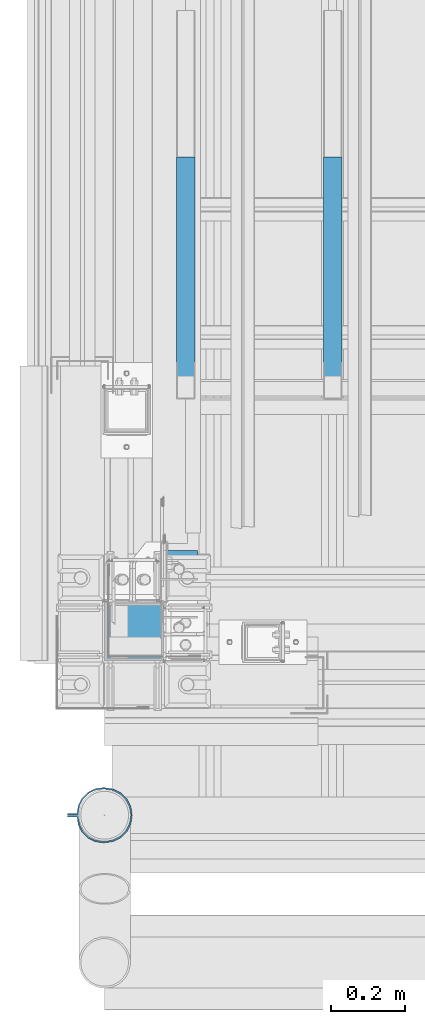
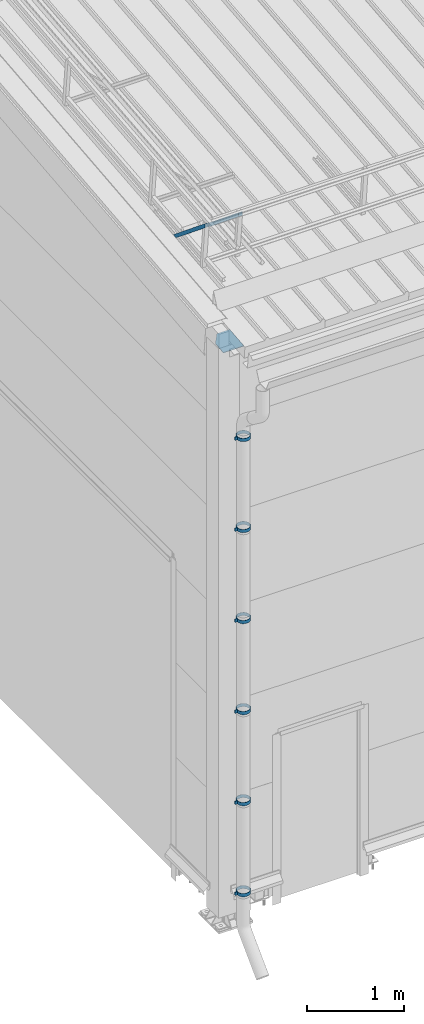
# One storey, part 290 of 709: 7 beams, 2 members, 9 elements without a shape of their own.
"""IFC4 building model written with IfcOpenShell, lengths in millimetres."""

import ifcopenshell
import ifcopenshell.guid

model = None  # the IFC model being written
_history = None  # IfcOwnerHistory: only IFC2X3 demands one
_inside = {}  # id of a spatial element -> (the spatial element, [elements in it])
_under = {}  # id of a project, library or spatial element -> (it, [spatial elements below it])
_declared = {}  # id of a project -> (the project, [libraries it declares])
_typed = {}  # id of a type object -> (the type object, [elements of that type])
_made_of = {}  # id of a material, layer set ... -> (it, [elements and type objects made of it])


def new_model(schema):
    """Start an empty IFC model of exactly this schema.

    Asked for "IFC4X3", IfcOpenShell would pick the latest addendum, in which some entities
    have other attributes; the version numbers below select the first issue.
    IFC2X3 requires an IfcOwnerHistory on every rooted entity: one is made here for all.
    """
    global model, _history
    if schema == "IFC4X3":
        model = ifcopenshell.file(schema_version=(4, 3, 0, 0))
    else:
        model = ifcopenshell.file(schema=schema)
    _inside.clear()
    _under.clear()
    _declared.clear()
    _typed.clear()
    _made_of.clear()
    _history = None
    if model.schema == "IFC2X3":
        org = make("IfcOrganization", Name="unknown")
        user = make(
            "IfcPersonAndOrganization",
            ThePerson=make("IfcPerson", FamilyName="unknown"),
            TheOrganization=org,
        )
        app = make(
            "IfcApplication",
            ApplicationDeveloper=org,
            Version="unknown",
            ApplicationFullName="unknown",
            ApplicationIdentifier="unknown",
        )
        _history = make(
            "IfcOwnerHistory",
            OwningUser=user,
            OwningApplication=app,
            ChangeAction="ADDED",
            CreationDate=0,
        )
    return model


def make(cls, **values):
    """One entity of the class cls with the attributes given. An attribute that is None is left unset."""
    return model.create_entity(
        cls, **{name: value for name, value in values.items() if value is not None}
    )


def rooted(cls, **values):
    """An entity with a GlobalId (a new one), such as an element, a storey or a relation."""
    return make(cls, GlobalId=ifcopenshell.guid.new(), OwnerHistory=_history, **values)


def si_unit(unit_type, name, prefix=None):
    """IfcSIUnit, for example si_unit("LENGTHUNIT", "METRE", prefix="MILLI")."""
    return make("IfcSIUnit", UnitType=unit_type, Prefix=prefix, Name=name)


def assignment(units):
    """IfcUnitAssignment: the units of a project."""
    return None if units is None else make("IfcUnitAssignment", Units=units)


def point(xyz):
    """IfcCartesianPoint."""
    return None if xyz is None else make("IfcCartesianPoint", Coordinates=xyz)


def direction(xyz):
    """IfcDirection."""
    return None if xyz is None else make("IfcDirection", DirectionRatios=xyz)


def frame(location, z_axis=None, x_axis=None):
    """IfcAxis2Placement3D, a coordinate frame: its origin and axes. An axis left out is left unset."""
    return make(
        "IfcAxis2Placement3D",
        Location=point(location),
        Axis=direction(z_axis),
        RefDirection=direction(x_axis),
    )


def origin_with_axes():
    """The frame at (0, 0, 0) with the z axis (0, 0, 1) and the x axis (1, 0, 0) written out."""
    return frame((0.0, 0.0, 0.0), z_axis=(0.0, 0.0, 1.0), x_axis=(1.0, 0.0, 0.0))


def place(relative_to, where):
    """IfcLocalPlacement: puts the frame where relative to a parent placement (None: the world)."""
    return make(
        "IfcLocalPlacement", PlacementRelTo=relative_to, RelativePlacement=where
    )


def context(
    kind, dimensions, precision=None, world=None, true_north=None, identifier=None
):
    """IfcGeometricRepresentationContext, for example the 3D "Model" context."""
    return make(
        "IfcGeometricRepresentationContext",
        ContextIdentifier=identifier,
        ContextType=kind,
        CoordinateSpaceDimension=dimensions,
        Precision=precision,
        WorldCoordinateSystem=world,
        TrueNorth=true_north,
    )


def subcontext(parent, identifier, kind, view, scale=None):
    """IfcGeometricRepresentationSubContext, for example "Body" below "Model"."""
    return make(
        "IfcGeometricRepresentationSubContext",
        ContextIdentifier=identifier,
        ContextType=kind,
        ParentContext=parent,
        TargetScale=scale,
        TargetView=view,
    )


def project(units=None, contexts=None):
    """IfcProject with its units and contexts."""
    return rooted(
        "IfcProject",
        Name="project",
        RepresentationContexts=contexts,
        UnitsInContext=assignment(units),
    )


def spatial(cls, under=None, at=None, **own):
    """A site, building, storey or space (cls), placed at a placement, below another one or the project."""
    s = rooted(cls, ObjectPlacement=at, **own)
    if under is not None:
        _under.setdefault(under.id(), (under, []))[1].append(s)
    return s


def point_list(points):
    """IfcCartesianPointList2D or 3D."""
    cls = (
        "IfcCartesianPointList2D" if len(points[0]) == 2 else "IfcCartesianPointList3D"
    )
    return make(cls, CoordList=points)


def polygons(points, faces, closed=None, point_numbers=None):
    """IfcPolygonalFaceSet: a face is its outer loop, then its inner loops; points numbered from 1."""
    made = []
    for loops in faces:
        if len(loops) == 1:
            made.append(make("IfcIndexedPolygonalFace", CoordIndex=loops[0]))
        else:
            made.append(
                make(
                    "IfcIndexedPolygonalFaceWithVoids",
                    CoordIndex=loops[0],
                    InnerCoordIndices=loops[1:],
                )
            )
    return make(
        "IfcPolygonalFaceSet",
        Coordinates=point_list(points),
        Closed=closed,
        Faces=made,
        PnIndex=point_numbers,
    )


def shape(context_of_items, identifier, shape_type, items):
    """IfcShapeRepresentation: the items that make up one representation, for example the "Body"."""
    return make(
        "IfcShapeRepresentation",
        ContextOfItems=context_of_items,
        RepresentationIdentifier=identifier,
        RepresentationType=shape_type,
        Items=items,
    )


def material(Name=None, Category=None):
    """IfcMaterial."""
    return make("IfcMaterial", Name=Name, Category=Category)


def made_of(thing, what):
    """Note that an element or type object is made of a material, layer set ...; save() writes the relation."""
    if what is not None:
        _made_of.setdefault(what.id(), (what, []))[1].append(thing)
    return thing


def element(
    cls,
    number,
    at=None,
    inside=None,
    cuts=None,
    type_object=None,
    material=None,
    context=None,
    identifier="Body",
    shape_type=None,
    held_by="IfcProductDefinitionShape",
    body=None,
    shapes=None,
    **own,
):
    """One element of the class cls, such as IfcWall. Its Tag is "e" and its number.

    at: its placement. inside: the storey or other place that contains it. cuts: it is an
    opening in that element (IfcRelVoidsElement). A single representation is given by context,
    identifier, shape_type and body (its items); several are given by shapes. held_by: the class
    of the entity that holds the representations. save() writes the other relations.
    """
    e = rooted(cls, Tag="e%d" % number, ObjectPlacement=at, **own)
    if body is not None:
        shapes = [shape(context, identifier, shape_type, body)]
    if shapes is not None:
        e.Representation = make(held_by, Representations=shapes)
    if inside is not None:
        _inside.setdefault(inside.id(), (inside, []))[1].append(e)
    if cuts is not None:
        rooted(
            "IfcRelVoidsElement", RelatingBuildingElement=cuts, RelatedOpeningElement=e
        )
    if type_object is not None:
        _typed.setdefault(type_object.id(), (type_object, []))[1].append(e)
    return made_of(e, material)


def aggregate(whole, parts):
    """IfcRelAggregates: a whole, such as a stair, and the parts it consists of."""
    return rooted("IfcRelAggregates", RelatingObject=whole, RelatedObjects=parts)


def save(model, path):
    """Write the relations noted so far, then the file.

    IfcRelAggregates (storeys below a building ...), IfcRelContainedInSpatialStructure (elements
    in a storey), IfcRelDefinesByType, IfcRelAssociatesMaterial and IfcRelDeclares: one each for
    every whole, place, type object, material and project.
    """
    for whole, parts in _under.values():
        aggregate(whole, parts)
    for where, things in _inside.values():
        rooted(
            "IfcRelContainedInSpatialStructure",
            RelatedElements=things,
            RelatingStructure=where,
        )
    for kind, things in _typed.values():
        rooted("IfcRelDefinesByType", RelatedObjects=things, RelatingType=kind)
    for what, things in _made_of.values():
        rooted("IfcRelAssociatesMaterial", RelatedObjects=things, RelatingMaterial=what)
    for by, libraries in _declared.values():
        rooted("IfcRelDeclares", RelatingContext=by, RelatedDefinitions=libraries)
    model.write(path)


model = new_model("IFC4")

# Units and contexts
model_context = context("Model", 3, precision=0.2, world=origin_with_axes(), true_north=direction((0.0, 1.0)))
body_context = subcontext(model_context, "Body", "Model", "MODEL_VIEW")
ifc_project = project(units=[si_unit("LENGTHUNIT", "METRE", prefix="MILLI"), si_unit("AREAUNIT", "SQUARE_METRE"), si_unit("VOLUMEUNIT", "CUBIC_METRE"), si_unit("MASSUNIT", "GRAM", prefix="KILO"), si_unit("TIMEUNIT", "SECOND"), si_unit("PLANEANGLEUNIT", "RADIAN"), si_unit("SOLIDANGLEUNIT", "STERADIAN"), si_unit("THERMODYNAMICTEMPERATUREUNIT", "DEGREE_CELSIUS"), si_unit("LUMINOUSINTENSITYUNIT", "LUMEN")], contexts=[model_context])

# Site, building, storey
site_placement = place(None, origin_with_axes())
site = spatial("IfcSite", under=ifc_project, at=site_placement, CompositionType="ELEMENT")
building_placement = place(site_placement, origin_with_axes())
building = spatial("IfcBuilding", under=site, at=building_placement, Name="Undefined", CompositionType="ELEMENT")
storey_placement = place(building_placement, origin_with_axes())
storey = spatial("IfcBuildingStorey", under=building, at=storey_placement, Name="Undefined", CompositionType="ELEMENT", Elevation=0.0)

# Assembly, beam
assembly_1_placement = place(storey_placement, frame((80.0, 80.0, -200.0), z_axis=(0.0, -1.0, 0.0), x_axis=(0.0, 0.0, 1.0)))
assembly_1 = element("IfcElementAssembly", 1, at=assembly_1_placement, inside=storey)
ifc_material_1 = material(Name="C355-6", Category="STEEL")
beam_1_placement = place(assembly_1_placement, frame((7216.36323, -48.5, 75.42283), z_axis=(0.9950371902, 0.0, 0.099503719), x_axis=(0.099503719, 0.0, -0.9950371902)))
beam_1 = element("IfcBeam", 2, at=beam_1_placement, material=ifc_material_1, ObjectType="454", context=body_context, shape_type="Tessellation", body=[
    polygons([(0.0, -123.5, 4.0), (0.0, 123.5, 4.0), (0.0, 123.5, -4.0), (0.0, -123.5, -4.0), (295.99751, -123.5, -4.0), (295.99751, -123.5, 4.0), (295.99751, 31.06708, 4.0), (166.2459, 123.5, 4.0), (166.2459, 123.5, -4.0), (295.99751, 31.06708, -4.0)], [[[1, 2, 3, 4]], [[1, 4, 5, 6]], [[2, 1, 6, 7, 8]], [[3, 2, 8, 9]], [[5, 4, 3, 9, 10]], [[6, 5, 10, 7]], [[9, 8, 7, 10]]], closed=True),
])
aggregate(assembly_1, [beam_1])

# Assembly, member
assembly_2_placement = place(storey_placement, frame((220.0, 1355.27062, 7601.48425), z_axis=(0.0, -0.6332377902, -0.7739572992), x_axis=(0.0, -0.7739572992, 0.6332377902)))
assembly_2 = element("IfcElementAssembly", 3, at=assembly_2_placement, inside=storey)
ifc_material_2 = material(Name="Steel_Undefined", Category="STEEL")
member_1_placement = place(assembly_2_placement, origin_with_axes())
member_1 = element("IfcMember", 4, at=member_1_placement, material=ifc_material_2, ObjectType="603", context=body_context, shape_type="Tessellation", body=[
    polygons([(0.0, -25.0, -20.0), (0.0, 25.0, -20.0), (848.52814, 25.0, -20.0), (848.52814, -25.0, -20.0), (40.0, 25.0, 20.0), (808.52814, 25.0, 20.0), (40.0, 22.5, 20.0), (808.52814, 22.5, 20.0), (2.5, 22.5, -17.5), (846.02814, 22.5, -17.5), (2.5, -22.5, -17.5), (846.02814, -22.5, -17.5), (40.0, -22.5, 20.0), (808.52814, -22.5, 20.0), (40.0, -25.0, 20.0), (808.52814, -25.0, 20.0)], [[[1, 2, 3, 4]], [[2, 5, 6, 3]], [[5, 7, 8, 6]], [[7, 9, 10, 8]], [[9, 11, 12, 10]], [[11, 13, 14, 12]], [[13, 15, 16, 14]], [[15, 1, 4, 16]], [[6, 8, 10, 12, 14, 16, 4, 3]], [[15, 13, 11, 9, 7, 5, 2, 1]]], closed=True),
])
aggregate(assembly_2, [member_1])

assembly_3_placement = place(storey_placement, frame((620.0, 1355.27062, 7601.48425), z_axis=(0.0, -0.6332377902, -0.7739572992), x_axis=(0.0, -0.7739572992, 0.6332377902)))
assembly_3 = element("IfcElementAssembly", 5, at=assembly_3_placement, inside=storey)
member_2_placement = place(assembly_3_placement, origin_with_axes())
member_2 = element("IfcMember", 6, at=member_2_placement, material=ifc_material_2, ObjectType="603", context=body_context, shape_type="Tessellation", body=[
    polygons([(0.0, -25.0, -20.0), (0.0, 25.0, -20.0), (848.52814, 25.0, -20.0), (848.52814, -25.0, -20.0), (40.0, 25.0, 20.0), (808.52814, 25.0, 20.0), (40.0, 22.5, 20.0), (808.52814, 22.5, 20.0), (2.5, 22.5, -17.5), (846.02814, 22.5, -17.5), (2.5, -22.5, -17.5), (846.02814, -22.5, -17.5), (40.0, -22.5, 20.0), (808.52814, -22.5, 20.0), (40.0, -25.0, 20.0), (808.52814, -25.0, 20.0)], [[[1, 2, 3, 4]], [[2, 5, 6, 3]], [[5, 7, 8, 6]], [[7, 9, 10, 8]], [[9, 11, 12, 10]], [[11, 13, 14, 12]], [[13, 15, 16, 14]], [[15, 1, 4, 16]], [[6, 8, 10, 12, 14, 16, 4, 3]], [[15, 13, 11, 9, 7, 5, 2, 1]]], closed=True),
])
aggregate(assembly_3, [member_2])

# Assembly, beam
assembly_4_placement = place(storey_placement, frame((-101.0, -422.5, 6226.92297), z_axis=(0.0, -1.0, 0.0), x_axis=(1.0, 0.0, 0.0)))
assembly_4 = element("IfcElementAssembly", 7, at=assembly_4_placement, inside=storey)
beam_2_placement = place(assembly_4_placement, origin_with_axes())
beam_2 = element("IfcBeam", 8, at=beam_2_placement, material=ifc_material_2, ObjectType="616", context=body_context, shape_type="Tessellation", body=[
    polygons([(0.0, -20.0, 2.0), (0.0, 20.0, 2.0), (0.0, 20.0, -2.0), (0.0, -20.0, -2.0), (30.0, 20.0, -2.0), (30.0, -20.0, -2.0), (26.0, -20.0, 2.0), (26.0, 20.0, 2.0), (30.0, 20.0, 3.5), (30.0, -20.0, 3.5), (26.0, -20.0, 3.5), (26.0, 20.0, 3.5), (33.18133, 20.0, 23.5861), (33.18133, -20.0, 23.5861), (29.3771, -20.0, 24.82217), (29.3771, 20.0, 24.82217), (39.17783, -20.0, 44.05718), (39.17783, 20.0, 44.05718), (42.4139, 20.0, 41.70604), (42.4139, -20.0, 41.70604), (54.44282, -20.0, 59.32217), (54.44282, 20.0, 59.32217), (56.79396, 20.0, 56.0861), (56.79396, -20.0, 56.0861), (73.67783, -20.0, 69.1229), (73.67783, 20.0, 69.1229), (74.9139, 20.0, 65.31867), (74.9139, -20.0, 65.31867), (95.0, -20.0, 72.5), (95.0, 20.0, 72.5), (95.0, 20.0, 68.5), (95.0, -20.0, 68.5), (102.0, 20.0, 68.5), (102.0, -20.0, 68.5), (102.0, -20.0, 72.5), (102.0, 20.0, 72.5), (123.63119, 20.0, 65.07396), (123.63119, -20.0, 65.07396), (124.86726, -20.0, 68.87818), (124.86726, 20.0, 68.87818), (145.49611, -20.0, 58.36726), (145.49611, 20.0, 58.36726), (143.14497, 20.0, 55.13119), (143.14497, -20.0, 55.13119), (161.86726, -20.0, 41.99611), (161.86726, 20.0, 41.99611), (158.63119, 20.0, 39.64497), (158.63119, -20.0, 39.64497), (172.37818, -20.0, 21.36726), (172.37818, 20.0, 21.36726), (168.57396, 20.0, 20.13119), (168.57396, -20.0, 20.13119), (176.0, -20.0, -1.5), (176.0, 20.0, -1.5), (172.0, 20.0, -1.5), (172.0, -20.0, -1.5), (172.0, 20.0, -3.5), (172.0, -20.0, -3.5), (176.0, -20.0, -3.5), (176.0, 20.0, -3.5), (168.57396, 20.0, -25.13119), (168.57396, -20.0, -25.13119), (172.37818, -20.0, -26.36726), (172.37818, 20.0, -26.36726), (161.86726, -20.0, -46.99611), (161.86726, 20.0, -46.99611), (158.63119, 20.0, -44.64497), (158.63119, -20.0, -44.64497), (145.49611, -20.0, -63.36726), (145.49611, 20.0, -63.36726), (143.14497, 20.0, -60.13119), (143.14497, -20.0, -60.13119), (124.86726, -20.0, -73.87818), (124.86726, 20.0, -73.87818), (123.63119, 20.0, -70.07396), (123.63119, -20.0, -70.07396), (102.0, -20.0, -77.5), (102.0, 20.0, -77.5), (102.0, 20.0, -73.5), (102.0, -20.0, -73.5), (95.0, 20.0, -73.5), (95.0, -20.0, -73.5), (95.0, -20.0, -77.5), (95.0, 20.0, -77.5), (74.9139, 20.0, -70.31867), (74.9139, -20.0, -70.31867), (73.67783, -20.0, -74.1229), (73.67783, 20.0, -74.1229), (54.44282, -20.0, -64.32217), (54.44282, 20.0, -64.32217), (56.79396, 20.0, -61.0861), (56.79396, -20.0, -61.0861), (39.17783, -20.0, -49.05718), (39.17783, 20.0, -49.05718), (42.4139, 20.0, -46.70604), (42.4139, -20.0, -46.70604), (29.3771, -20.0, -29.82217), (29.3771, 20.0, -29.82217), (33.18133, 20.0, -28.5861), (33.18133, -20.0, -28.5861), (26.0, -20.0, -8.5), (26.0, 20.0, -8.5), (30.0, 20.0, -8.5), (30.0, -20.0, -8.5), (30.0, 20.0, -3.0), (30.0, -20.0, -3.0), (26.0, -20.0, -7.0), (26.0, 20.0, -7.0), (0.0, 20.0, -3.0), (0.0, -20.0, -3.0), (0.0, 20.0, -7.0), (0.0, -20.0, -7.0)], [[[1, 2, 3, 4]], [[4, 3, 5, 6]], [[2, 1, 7, 8]], [[6, 5, 9, 10]], [[8, 7, 11, 12]], [[10, 9, 13, 14]], [[12, 11, 15, 16]], [[15, 17, 18, 16]], [[13, 19, 20, 14]], [[17, 21, 22, 18]], [[19, 23, 24, 20]], [[21, 25, 26, 22]], [[23, 27, 28, 24]], [[25, 29, 30, 26]], [[27, 31, 32, 28]], [[32, 31, 33, 34]], [[30, 29, 35, 36]], [[34, 33, 37, 38]], [[36, 35, 39, 40]], [[39, 41, 42, 40]], [[37, 43, 44, 38]], [[41, 45, 46, 42]], [[43, 47, 48, 44]], [[45, 49, 50, 46]], [[47, 51, 52, 48]], [[49, 53, 54, 50]], [[51, 55, 56, 52]], [[56, 55, 57, 58]], [[54, 53, 59, 60]], [[58, 57, 61, 62]], [[60, 59, 63, 64]], [[63, 65, 66, 64]], [[61, 67, 68, 62]], [[65, 69, 70, 66]], [[67, 71, 72, 68]], [[69, 73, 74, 70]], [[71, 75, 76, 72]], [[73, 77, 78, 74]], [[75, 79, 80, 76]], [[80, 79, 81, 82]], [[78, 77, 83, 84]], [[82, 81, 85, 86]], [[84, 83, 87, 88]], [[87, 89, 90, 88]], [[85, 91, 92, 86]], [[89, 93, 94, 90]], [[91, 95, 96, 92]], [[93, 97, 98, 94]], [[95, 99, 100, 96]], [[97, 101, 102, 98]], [[99, 103, 104, 100]], [[104, 103, 105, 106]], [[102, 101, 107, 108]], [[106, 105, 109, 110]], [[105, 103, 99, 95, 91, 85, 81, 79, 75, 71, 67, 61, 57, 55, 51, 47, 43, 37, 33, 31, 27, 23, 19, 13, 9, 5, 3, 2, 8, 12, 16, 18, 22, 26, 30, 36, 40, 42, 46, 50, 54, 60, 64, 66, 70, 74, 78, 84, 88, 90, 94, 98, 102, 108, 111, 109]], [[108, 107, 112, 111]], [[107, 101, 97, 93, 89, 87, 83, 77, 73, 69, 65, 63, 59, 53, 49, 45, 41, 39, 35, 29, 25, 21, 17, 15, 11, 7, 1, 4, 6, 10, 14, 20, 24, 28, 32, 34, 38, 44, 48, 52, 56, 58, 62, 68, 72, 76, 80, 82, 86, 92, 96, 100, 104, 106, 110, 112]], [[111, 112, 110, 109]]], closed=True),
])
aggregate(assembly_4, [beam_2])

assembly_5_placement = place(storey_placement, frame((-101.0, -422.5, 5076.92297), z_axis=(0.0, -1.0, 0.0), x_axis=(1.0, 0.0, 0.0)))
assembly_5 = element("IfcElementAssembly", 9, at=assembly_5_placement, inside=storey)
beam_3_placement = place(assembly_5_placement, origin_with_axes())
beam_3 = element("IfcBeam", 10, at=beam_3_placement, material=ifc_material_2, ObjectType="616", context=body_context, shape_type="Tessellation", body=[
    polygons([(0.0, -20.0, 2.0), (0.0, 20.0, 2.0), (0.0, 20.0, -2.0), (0.0, -20.0, -2.0), (30.0, 20.0, -2.0), (30.0, -20.0, -2.0), (26.0, -20.0, 2.0), (26.0, 20.0, 2.0), (30.0, 20.0, 3.5), (30.0, -20.0, 3.5), (26.0, -20.0, 3.5), (26.0, 20.0, 3.5), (33.18133, 20.0, 23.5861), (33.18133, -20.0, 23.5861), (29.3771, -20.0, 24.82217), (29.3771, 20.0, 24.82217), (39.17783, -20.0, 44.05718), (39.17783, 20.0, 44.05718), (42.4139, 20.0, 41.70604), (42.4139, -20.0, 41.70604), (54.44282, -20.0, 59.32217), (54.44282, 20.0, 59.32217), (56.79396, 20.0, 56.0861), (56.79396, -20.0, 56.0861), (73.67783, -20.0, 69.1229), (73.67783, 20.0, 69.1229), (74.9139, 20.0, 65.31867), (74.9139, -20.0, 65.31867), (95.0, -20.0, 72.5), (95.0, 20.0, 72.5), (95.0, 20.0, 68.5), (95.0, -20.0, 68.5), (102.0, 20.0, 68.5), (102.0, -20.0, 68.5), (102.0, -20.0, 72.5), (102.0, 20.0, 72.5), (123.63119, 20.0, 65.07396), (123.63119, -20.0, 65.07396), (124.86726, -20.0, 68.87818), (124.86726, 20.0, 68.87818), (145.49611, -20.0, 58.36726), (145.49611, 20.0, 58.36726), (143.14497, 20.0, 55.13119), (143.14497, -20.0, 55.13119), (161.86726, -20.0, 41.99611), (161.86726, 20.0, 41.99611), (158.63119, 20.0, 39.64497), (158.63119, -20.0, 39.64497), (172.37818, -20.0, 21.36726), (172.37818, 20.0, 21.36726), (168.57396, 20.0, 20.13119), (168.57396, -20.0, 20.13119), (176.0, -20.0, -1.5), (176.0, 20.0, -1.5), (172.0, 20.0, -1.5), (172.0, -20.0, -1.5), (172.0, 20.0, -3.5), (172.0, -20.0, -3.5), (176.0, -20.0, -3.5), (176.0, 20.0, -3.5), (168.57396, 20.0, -25.13119), (168.57396, -20.0, -25.13119), (172.37818, -20.0, -26.36726), (172.37818, 20.0, -26.36726), (161.86726, -20.0, -46.99611), (161.86726, 20.0, -46.99611), (158.63119, 20.0, -44.64497), (158.63119, -20.0, -44.64497), (145.49611, -20.0, -63.36726), (145.49611, 20.0, -63.36726), (143.14497, 20.0, -60.13119), (143.14497, -20.0, -60.13119), (124.86726, -20.0, -73.87818), (124.86726, 20.0, -73.87818), (123.63119, 20.0, -70.07396), (123.63119, -20.0, -70.07396), (102.0, -20.0, -77.5), (102.0, 20.0, -77.5), (102.0, 20.0, -73.5), (102.0, -20.0, -73.5), (95.0, 20.0, -73.5), (95.0, -20.0, -73.5), (95.0, -20.0, -77.5), (95.0, 20.0, -77.5), (74.9139, 20.0, -70.31867), (74.9139, -20.0, -70.31867), (73.67783, -20.0, -74.1229), (73.67783, 20.0, -74.1229), (54.44282, -20.0, -64.32217), (54.44282, 20.0, -64.32217), (56.79396, 20.0, -61.0861), (56.79396, -20.0, -61.0861), (39.17783, -20.0, -49.05718), (39.17783, 20.0, -49.05718), (42.4139, 20.0, -46.70604), (42.4139, -20.0, -46.70604), (29.3771, -20.0, -29.82217), (29.3771, 20.0, -29.82217), (33.18133, 20.0, -28.5861), (33.18133, -20.0, -28.5861), (26.0, -20.0, -8.5), (26.0, 20.0, -8.5), (30.0, 20.0, -8.5), (30.0, -20.0, -8.5), (30.0, 20.0, -3.0), (30.0, -20.0, -3.0), (26.0, -20.0, -7.0), (26.0, 20.0, -7.0), (0.0, 20.0, -3.0), (0.0, -20.0, -3.0), (0.0, 20.0, -7.0), (0.0, -20.0, -7.0)], [[[1, 2, 3, 4]], [[4, 3, 5, 6]], [[2, 1, 7, 8]], [[6, 5, 9, 10]], [[8, 7, 11, 12]], [[10, 9, 13, 14]], [[12, 11, 15, 16]], [[15, 17, 18, 16]], [[13, 19, 20, 14]], [[17, 21, 22, 18]], [[19, 23, 24, 20]], [[21, 25, 26, 22]], [[23, 27, 28, 24]], [[25, 29, 30, 26]], [[27, 31, 32, 28]], [[32, 31, 33, 34]], [[30, 29, 35, 36]], [[34, 33, 37, 38]], [[36, 35, 39, 40]], [[39, 41, 42, 40]], [[37, 43, 44, 38]], [[41, 45, 46, 42]], [[43, 47, 48, 44]], [[45, 49, 50, 46]], [[47, 51, 52, 48]], [[49, 53, 54, 50]], [[51, 55, 56, 52]], [[56, 55, 57, 58]], [[54, 53, 59, 60]], [[58, 57, 61, 62]], [[60, 59, 63, 64]], [[63, 65, 66, 64]], [[61, 67, 68, 62]], [[65, 69, 70, 66]], [[67, 71, 72, 68]], [[69, 73, 74, 70]], [[71, 75, 76, 72]], [[73, 77, 78, 74]], [[75, 79, 80, 76]], [[80, 79, 81, 82]], [[78, 77, 83, 84]], [[82, 81, 85, 86]], [[84, 83, 87, 88]], [[87, 89, 90, 88]], [[85, 91, 92, 86]], [[89, 93, 94, 90]], [[91, 95, 96, 92]], [[93, 97, 98, 94]], [[95, 99, 100, 96]], [[97, 101, 102, 98]], [[99, 103, 104, 100]], [[104, 103, 105, 106]], [[102, 101, 107, 108]], [[106, 105, 109, 110]], [[105, 103, 99, 95, 91, 85, 81, 79, 75, 71, 67, 61, 57, 55, 51, 47, 43, 37, 33, 31, 27, 23, 19, 13, 9, 5, 3, 2, 8, 12, 16, 18, 22, 26, 30, 36, 40, 42, 46, 50, 54, 60, 64, 66, 70, 74, 78, 84, 88, 90, 94, 98, 102, 108, 111, 109]], [[108, 107, 112, 111]], [[107, 101, 97, 93, 89, 87, 83, 77, 73, 69, 65, 63, 59, 53, 49, 45, 41, 39, 35, 29, 25, 21, 17, 15, 11, 7, 1, 4, 6, 10, 14, 20, 24, 28, 32, 34, 38, 44, 48, 52, 56, 58, 62, 68, 72, 76, 80, 82, 86, 92, 96, 100, 104, 106, 110, 112]], [[111, 112, 110, 109]]], closed=True),
])
aggregate(assembly_5, [beam_3])

assembly_6_placement = place(storey_placement, frame((-101.0, -422.5, 3926.92297), z_axis=(0.0, -1.0, 0.0), x_axis=(1.0, 0.0, 0.0)))
assembly_6 = element("IfcElementAssembly", 11, at=assembly_6_placement, inside=storey)
beam_4_placement = place(assembly_6_placement, origin_with_axes())
beam_4 = element("IfcBeam", 12, at=beam_4_placement, material=ifc_material_2, ObjectType="616", context=body_context, shape_type="Tessellation", body=[
    polygons([(0.0, -20.0, 2.0), (0.0, 20.0, 2.0), (0.0, 20.0, -2.0), (0.0, -20.0, -2.0), (30.0, 20.0, -2.0), (30.0, -20.0, -2.0), (26.0, -20.0, 2.0), (26.0, 20.0, 2.0), (30.0, 20.0, 3.5), (30.0, -20.0, 3.5), (26.0, -20.0, 3.5), (26.0, 20.0, 3.5), (33.18133, 20.0, 23.5861), (33.18133, -20.0, 23.5861), (29.3771, -20.0, 24.82217), (29.3771, 20.0, 24.82217), (39.17783, -20.0, 44.05718), (39.17783, 20.0, 44.05718), (42.4139, 20.0, 41.70604), (42.4139, -20.0, 41.70604), (54.44282, -20.0, 59.32217), (54.44282, 20.0, 59.32217), (56.79396, 20.0, 56.0861), (56.79396, -20.0, 56.0861), (73.67783, -20.0, 69.1229), (73.67783, 20.0, 69.1229), (74.9139, 20.0, 65.31867), (74.9139, -20.0, 65.31867), (95.0, -20.0, 72.5), (95.0, 20.0, 72.5), (95.0, 20.0, 68.5), (95.0, -20.0, 68.5), (102.0, 20.0, 68.5), (102.0, -20.0, 68.5), (102.0, -20.0, 72.5), (102.0, 20.0, 72.5), (123.63119, 20.0, 65.07396), (123.63119, -20.0, 65.07396), (124.86726, -20.0, 68.87818), (124.86726, 20.0, 68.87818), (145.49611, -20.0, 58.36726), (145.49611, 20.0, 58.36726), (143.14497, 20.0, 55.13119), (143.14497, -20.0, 55.13119), (161.86726, -20.0, 41.99611), (161.86726, 20.0, 41.99611), (158.63119, 20.0, 39.64497), (158.63119, -20.0, 39.64497), (172.37818, -20.0, 21.36726), (172.37818, 20.0, 21.36726), (168.57396, 20.0, 20.13119), (168.57396, -20.0, 20.13119), (176.0, -20.0, -1.5), (176.0, 20.0, -1.5), (172.0, 20.0, -1.5), (172.0, -20.0, -1.5), (172.0, 20.0, -3.5), (172.0, -20.0, -3.5), (176.0, -20.0, -3.5), (176.0, 20.0, -3.5), (168.57396, 20.0, -25.13119), (168.57396, -20.0, -25.13119), (172.37818, -20.0, -26.36726), (172.37818, 20.0, -26.36726), (161.86726, -20.0, -46.99611), (161.86726, 20.0, -46.99611), (158.63119, 20.0, -44.64497), (158.63119, -20.0, -44.64497), (145.49611, -20.0, -63.36726), (145.49611, 20.0, -63.36726), (143.14497, 20.0, -60.13119), (143.14497, -20.0, -60.13119), (124.86726, -20.0, -73.87818), (124.86726, 20.0, -73.87818), (123.63119, 20.0, -70.07396), (123.63119, -20.0, -70.07396), (102.0, -20.0, -77.5), (102.0, 20.0, -77.5), (102.0, 20.0, -73.5), (102.0, -20.0, -73.5), (95.0, 20.0, -73.5), (95.0, -20.0, -73.5), (95.0, -20.0, -77.5), (95.0, 20.0, -77.5), (74.9139, 20.0, -70.31867), (74.9139, -20.0, -70.31867), (73.67783, -20.0, -74.1229), (73.67783, 20.0, -74.1229), (54.44282, -20.0, -64.32217), (54.44282, 20.0, -64.32217), (56.79396, 20.0, -61.0861), (56.79396, -20.0, -61.0861), (39.17783, -20.0, -49.05718), (39.17783, 20.0, -49.05718), (42.4139, 20.0, -46.70604), (42.4139, -20.0, -46.70604), (29.3771, -20.0, -29.82217), (29.3771, 20.0, -29.82217), (33.18133, 20.0, -28.5861), (33.18133, -20.0, -28.5861), (26.0, -20.0, -8.5), (26.0, 20.0, -8.5), (30.0, 20.0, -8.5), (30.0, -20.0, -8.5), (30.0, 20.0, -3.0), (30.0, -20.0, -3.0), (26.0, -20.0, -7.0), (26.0, 20.0, -7.0), (0.0, 20.0, -3.0), (0.0, -20.0, -3.0), (0.0, 20.0, -7.0), (0.0, -20.0, -7.0)], [[[1, 2, 3, 4]], [[4, 3, 5, 6]], [[2, 1, 7, 8]], [[6, 5, 9, 10]], [[8, 7, 11, 12]], [[10, 9, 13, 14]], [[12, 11, 15, 16]], [[15, 17, 18, 16]], [[13, 19, 20, 14]], [[17, 21, 22, 18]], [[19, 23, 24, 20]], [[21, 25, 26, 22]], [[23, 27, 28, 24]], [[25, 29, 30, 26]], [[27, 31, 32, 28]], [[32, 31, 33, 34]], [[30, 29, 35, 36]], [[34, 33, 37, 38]], [[36, 35, 39, 40]], [[39, 41, 42, 40]], [[37, 43, 44, 38]], [[41, 45, 46, 42]], [[43, 47, 48, 44]], [[45, 49, 50, 46]], [[47, 51, 52, 48]], [[49, 53, 54, 50]], [[51, 55, 56, 52]], [[56, 55, 57, 58]], [[54, 53, 59, 60]], [[58, 57, 61, 62]], [[60, 59, 63, 64]], [[63, 65, 66, 64]], [[61, 67, 68, 62]], [[65, 69, 70, 66]], [[67, 71, 72, 68]], [[69, 73, 74, 70]], [[71, 75, 76, 72]], [[73, 77, 78, 74]], [[75, 79, 80, 76]], [[80, 79, 81, 82]], [[78, 77, 83, 84]], [[82, 81, 85, 86]], [[84, 83, 87, 88]], [[87, 89, 90, 88]], [[85, 91, 92, 86]], [[89, 93, 94, 90]], [[91, 95, 96, 92]], [[93, 97, 98, 94]], [[95, 99, 100, 96]], [[97, 101, 102, 98]], [[99, 103, 104, 100]], [[104, 103, 105, 106]], [[102, 101, 107, 108]], [[106, 105, 109, 110]], [[105, 103, 99, 95, 91, 85, 81, 79, 75, 71, 67, 61, 57, 55, 51, 47, 43, 37, 33, 31, 27, 23, 19, 13, 9, 5, 3, 2, 8, 12, 16, 18, 22, 26, 30, 36, 40, 42, 46, 50, 54, 60, 64, 66, 70, 74, 78, 84, 88, 90, 94, 98, 102, 108, 111, 109]], [[108, 107, 112, 111]], [[107, 101, 97, 93, 89, 87, 83, 77, 73, 69, 65, 63, 59, 53, 49, 45, 41, 39, 35, 29, 25, 21, 17, 15, 11, 7, 1, 4, 6, 10, 14, 20, 24, 28, 32, 34, 38, 44, 48, 52, 56, 58, 62, 68, 72, 76, 80, 82, 86, 92, 96, 100, 104, 106, 110, 112]], [[111, 112, 110, 109]]], closed=True),
])
aggregate(assembly_6, [beam_4])

assembly_7_placement = place(storey_placement, frame((-101.0, -422.5, 2776.92297), z_axis=(0.0, -1.0, 0.0), x_axis=(1.0, 0.0, 0.0)))
assembly_7 = element("IfcElementAssembly", 13, at=assembly_7_placement, inside=storey)
beam_5_placement = place(assembly_7_placement, origin_with_axes())
beam_5 = element("IfcBeam", 14, at=beam_5_placement, material=ifc_material_2, ObjectType="616", context=body_context, shape_type="Tessellation", body=[
    polygons([(0.0, -20.0, 2.0), (0.0, 20.0, 2.0), (0.0, 20.0, -2.0), (0.0, -20.0, -2.0), (30.0, 20.0, -2.0), (30.0, -20.0, -2.0), (26.0, -20.0, 2.0), (26.0, 20.0, 2.0), (30.0, 20.0, 3.5), (30.0, -20.0, 3.5), (26.0, -20.0, 3.5), (26.0, 20.0, 3.5), (33.18133, 20.0, 23.5861), (33.18133, -20.0, 23.5861), (29.3771, -20.0, 24.82217), (29.3771, 20.0, 24.82217), (39.17783, -20.0, 44.05718), (39.17783, 20.0, 44.05718), (42.4139, 20.0, 41.70604), (42.4139, -20.0, 41.70604), (54.44282, -20.0, 59.32217), (54.44282, 20.0, 59.32217), (56.79396, 20.0, 56.0861), (56.79396, -20.0, 56.0861), (73.67783, -20.0, 69.1229), (73.67783, 20.0, 69.1229), (74.9139, 20.0, 65.31867), (74.9139, -20.0, 65.31867), (95.0, -20.0, 72.5), (95.0, 20.0, 72.5), (95.0, 20.0, 68.5), (95.0, -20.0, 68.5), (102.0, 20.0, 68.5), (102.0, -20.0, 68.5), (102.0, -20.0, 72.5), (102.0, 20.0, 72.5), (123.63119, 20.0, 65.07396), (123.63119, -20.0, 65.07396), (124.86726, -20.0, 68.87818), (124.86726, 20.0, 68.87818), (145.49611, -20.0, 58.36726), (145.49611, 20.0, 58.36726), (143.14497, 20.0, 55.13119), (143.14497, -20.0, 55.13119), (161.86726, -20.0, 41.99611), (161.86726, 20.0, 41.99611), (158.63119, 20.0, 39.64497), (158.63119, -20.0, 39.64497), (172.37818, -20.0, 21.36726), (172.37818, 20.0, 21.36726), (168.57396, 20.0, 20.13119), (168.57396, -20.0, 20.13119), (176.0, -20.0, -1.5), (176.0, 20.0, -1.5), (172.0, 20.0, -1.5), (172.0, -20.0, -1.5), (172.0, 20.0, -3.5), (172.0, -20.0, -3.5), (176.0, -20.0, -3.5), (176.0, 20.0, -3.5), (168.57396, 20.0, -25.13119), (168.57396, -20.0, -25.13119), (172.37818, -20.0, -26.36726), (172.37818, 20.0, -26.36726), (161.86726, -20.0, -46.99611), (161.86726, 20.0, -46.99611), (158.63119, 20.0, -44.64497), (158.63119, -20.0, -44.64497), (145.49611, -20.0, -63.36726), (145.49611, 20.0, -63.36726), (143.14497, 20.0, -60.13119), (143.14497, -20.0, -60.13119), (124.86726, -20.0, -73.87818), (124.86726, 20.0, -73.87818), (123.63119, 20.0, -70.07396), (123.63119, -20.0, -70.07396), (102.0, -20.0, -77.5), (102.0, 20.0, -77.5), (102.0, 20.0, -73.5), (102.0, -20.0, -73.5), (95.0, 20.0, -73.5), (95.0, -20.0, -73.5), (95.0, -20.0, -77.5), (95.0, 20.0, -77.5), (74.9139, 20.0, -70.31867), (74.9139, -20.0, -70.31867), (73.67783, -20.0, -74.1229), (73.67783, 20.0, -74.1229), (54.44282, -20.0, -64.32217), (54.44282, 20.0, -64.32217), (56.79396, 20.0, -61.0861), (56.79396, -20.0, -61.0861), (39.17783, -20.0, -49.05718), (39.17783, 20.0, -49.05718), (42.4139, 20.0, -46.70604), (42.4139, -20.0, -46.70604), (29.3771, -20.0, -29.82217), (29.3771, 20.0, -29.82217), (33.18133, 20.0, -28.5861), (33.18133, -20.0, -28.5861), (26.0, -20.0, -8.5), (26.0, 20.0, -8.5), (30.0, 20.0, -8.5), (30.0, -20.0, -8.5), (30.0, 20.0, -3.0), (30.0, -20.0, -3.0), (26.0, -20.0, -7.0), (26.0, 20.0, -7.0), (0.0, 20.0, -3.0), (0.0, -20.0, -3.0), (0.0, 20.0, -7.0), (0.0, -20.0, -7.0)], [[[1, 2, 3, 4]], [[4, 3, 5, 6]], [[2, 1, 7, 8]], [[6, 5, 9, 10]], [[8, 7, 11, 12]], [[10, 9, 13, 14]], [[12, 11, 15, 16]], [[15, 17, 18, 16]], [[13, 19, 20, 14]], [[17, 21, 22, 18]], [[19, 23, 24, 20]], [[21, 25, 26, 22]], [[23, 27, 28, 24]], [[25, 29, 30, 26]], [[27, 31, 32, 28]], [[32, 31, 33, 34]], [[30, 29, 35, 36]], [[34, 33, 37, 38]], [[36, 35, 39, 40]], [[39, 41, 42, 40]], [[37, 43, 44, 38]], [[41, 45, 46, 42]], [[43, 47, 48, 44]], [[45, 49, 50, 46]], [[47, 51, 52, 48]], [[49, 53, 54, 50]], [[51, 55, 56, 52]], [[56, 55, 57, 58]], [[54, 53, 59, 60]], [[58, 57, 61, 62]], [[60, 59, 63, 64]], [[63, 65, 66, 64]], [[61, 67, 68, 62]], [[65, 69, 70, 66]], [[67, 71, 72, 68]], [[69, 73, 74, 70]], [[71, 75, 76, 72]], [[73, 77, 78, 74]], [[75, 79, 80, 76]], [[80, 79, 81, 82]], [[78, 77, 83, 84]], [[82, 81, 85, 86]], [[84, 83, 87, 88]], [[87, 89, 90, 88]], [[85, 91, 92, 86]], [[89, 93, 94, 90]], [[91, 95, 96, 92]], [[93, 97, 98, 94]], [[95, 99, 100, 96]], [[97, 101, 102, 98]], [[99, 103, 104, 100]], [[104, 103, 105, 106]], [[102, 101, 107, 108]], [[106, 105, 109, 110]], [[105, 103, 99, 95, 91, 85, 81, 79, 75, 71, 67, 61, 57, 55, 51, 47, 43, 37, 33, 31, 27, 23, 19, 13, 9, 5, 3, 2, 8, 12, 16, 18, 22, 26, 30, 36, 40, 42, 46, 50, 54, 60, 64, 66, 70, 74, 78, 84, 88, 90, 94, 98, 102, 108, 111, 109]], [[108, 107, 112, 111]], [[107, 101, 97, 93, 89, 87, 83, 77, 73, 69, 65, 63, 59, 53, 49, 45, 41, 39, 35, 29, 25, 21, 17, 15, 11, 7, 1, 4, 6, 10, 14, 20, 24, 28, 32, 34, 38, 44, 48, 52, 56, 58, 62, 68, 72, 76, 80, 82, 86, 92, 96, 100, 104, 106, 110, 112]], [[111, 112, 110, 109]]], closed=True),
])
aggregate(assembly_7, [beam_5])

assembly_8_placement = place(storey_placement, frame((-101.0, -422.5, 1626.92297), z_axis=(0.0, -1.0, 0.0), x_axis=(1.0, 0.0, 0.0)))
assembly_8 = element("IfcElementAssembly", 15, at=assembly_8_placement, inside=storey)
beam_6_placement = place(assembly_8_placement, origin_with_axes())
beam_6 = element("IfcBeam", 16, at=beam_6_placement, material=ifc_material_2, ObjectType="616", context=body_context, shape_type="Tessellation", body=[
    polygons([(0.0, -20.0, 2.0), (0.0, 20.0, 2.0), (0.0, 20.0, -2.0), (0.0, -20.0, -2.0), (30.0, 20.0, -2.0), (30.0, -20.0, -2.0), (26.0, -20.0, 2.0), (26.0, 20.0, 2.0), (30.0, 20.0, 3.5), (30.0, -20.0, 3.5), (26.0, -20.0, 3.5), (26.0, 20.0, 3.5), (33.18133, 20.0, 23.5861), (33.18133, -20.0, 23.5861), (29.3771, -20.0, 24.82217), (29.3771, 20.0, 24.82217), (39.17783, -20.0, 44.05718), (39.17783, 20.0, 44.05718), (42.4139, 20.0, 41.70604), (42.4139, -20.0, 41.70604), (54.44282, -20.0, 59.32217), (54.44282, 20.0, 59.32217), (56.79396, 20.0, 56.0861), (56.79396, -20.0, 56.0861), (73.67783, -20.0, 69.1229), (73.67783, 20.0, 69.1229), (74.9139, 20.0, 65.31867), (74.9139, -20.0, 65.31867), (95.0, -20.0, 72.5), (95.0, 20.0, 72.5), (95.0, 20.0, 68.5), (95.0, -20.0, 68.5), (102.0, 20.0, 68.5), (102.0, -20.0, 68.5), (102.0, -20.0, 72.5), (102.0, 20.0, 72.5), (123.63119, 20.0, 65.07396), (123.63119, -20.0, 65.07396), (124.86726, -20.0, 68.87818), (124.86726, 20.0, 68.87818), (145.49611, -20.0, 58.36726), (145.49611, 20.0, 58.36726), (143.14497, 20.0, 55.13119), (143.14497, -20.0, 55.13119), (161.86726, -20.0, 41.99611), (161.86726, 20.0, 41.99611), (158.63119, 20.0, 39.64497), (158.63119, -20.0, 39.64497), (172.37818, -20.0, 21.36726), (172.37818, 20.0, 21.36726), (168.57396, 20.0, 20.13119), (168.57396, -20.0, 20.13119), (176.0, -20.0, -1.5), (176.0, 20.0, -1.5), (172.0, 20.0, -1.5), (172.0, -20.0, -1.5), (172.0, 20.0, -3.5), (172.0, -20.0, -3.5), (176.0, -20.0, -3.5), (176.0, 20.0, -3.5), (168.57396, 20.0, -25.13119), (168.57396, -20.0, -25.13119), (172.37818, -20.0, -26.36726), (172.37818, 20.0, -26.36726), (161.86726, -20.0, -46.99611), (161.86726, 20.0, -46.99611), (158.63119, 20.0, -44.64497), (158.63119, -20.0, -44.64497), (145.49611, -20.0, -63.36726), (145.49611, 20.0, -63.36726), (143.14497, 20.0, -60.13119), (143.14497, -20.0, -60.13119), (124.86726, -20.0, -73.87818), (124.86726, 20.0, -73.87818), (123.63119, 20.0, -70.07396), (123.63119, -20.0, -70.07396), (102.0, -20.0, -77.5), (102.0, 20.0, -77.5), (102.0, 20.0, -73.5), (102.0, -20.0, -73.5), (95.0, 20.0, -73.5), (95.0, -20.0, -73.5), (95.0, -20.0, -77.5), (95.0, 20.0, -77.5), (74.9139, 20.0, -70.31867), (74.9139, -20.0, -70.31867), (73.67783, -20.0, -74.1229), (73.67783, 20.0, -74.1229), (54.44282, -20.0, -64.32217), (54.44282, 20.0, -64.32217), (56.79396, 20.0, -61.0861), (56.79396, -20.0, -61.0861), (39.17783, -20.0, -49.05718), (39.17783, 20.0, -49.05718), (42.4139, 20.0, -46.70604), (42.4139, -20.0, -46.70604), (29.3771, -20.0, -29.82217), (29.3771, 20.0, -29.82217), (33.18133, 20.0, -28.5861), (33.18133, -20.0, -28.5861), (26.0, -20.0, -8.5), (26.0, 20.0, -8.5), (30.0, 20.0, -8.5), (30.0, -20.0, -8.5), (30.0, 20.0, -3.0), (30.0, -20.0, -3.0), (26.0, -20.0, -7.0), (26.0, 20.0, -7.0), (0.0, 20.0, -3.0), (0.0, -20.0, -3.0), (0.0, 20.0, -7.0), (0.0, -20.0, -7.0)], [[[1, 2, 3, 4]], [[4, 3, 5, 6]], [[2, 1, 7, 8]], [[6, 5, 9, 10]], [[8, 7, 11, 12]], [[10, 9, 13, 14]], [[12, 11, 15, 16]], [[15, 17, 18, 16]], [[13, 19, 20, 14]], [[17, 21, 22, 18]], [[19, 23, 24, 20]], [[21, 25, 26, 22]], [[23, 27, 28, 24]], [[25, 29, 30, 26]], [[27, 31, 32, 28]], [[32, 31, 33, 34]], [[30, 29, 35, 36]], [[34, 33, 37, 38]], [[36, 35, 39, 40]], [[39, 41, 42, 40]], [[37, 43, 44, 38]], [[41, 45, 46, 42]], [[43, 47, 48, 44]], [[45, 49, 50, 46]], [[47, 51, 52, 48]], [[49, 53, 54, 50]], [[51, 55, 56, 52]], [[56, 55, 57, 58]], [[54, 53, 59, 60]], [[58, 57, 61, 62]], [[60, 59, 63, 64]], [[63, 65, 66, 64]], [[61, 67, 68, 62]], [[65, 69, 70, 66]], [[67, 71, 72, 68]], [[69, 73, 74, 70]], [[71, 75, 76, 72]], [[73, 77, 78, 74]], [[75, 79, 80, 76]], [[80, 79, 81, 82]], [[78, 77, 83, 84]], [[82, 81, 85, 86]], [[84, 83, 87, 88]], [[87, 89, 90, 88]], [[85, 91, 92, 86]], [[89, 93, 94, 90]], [[91, 95, 96, 92]], [[93, 97, 98, 94]], [[95, 99, 100, 96]], [[97, 101, 102, 98]], [[99, 103, 104, 100]], [[104, 103, 105, 106]], [[102, 101, 107, 108]], [[106, 105, 109, 110]], [[105, 103, 99, 95, 91, 85, 81, 79, 75, 71, 67, 61, 57, 55, 51, 47, 43, 37, 33, 31, 27, 23, 19, 13, 9, 5, 3, 2, 8, 12, 16, 18, 22, 26, 30, 36, 40, 42, 46, 50, 54, 60, 64, 66, 70, 74, 78, 84, 88, 90, 94, 98, 102, 108, 111, 109]], [[108, 107, 112, 111]], [[107, 101, 97, 93, 89, 87, 83, 77, 73, 69, 65, 63, 59, 53, 49, 45, 41, 39, 35, 29, 25, 21, 17, 15, 11, 7, 1, 4, 6, 10, 14, 20, 24, 28, 32, 34, 38, 44, 48, 52, 56, 58, 62, 68, 72, 76, 80, 82, 86, 92, 96, 100, 104, 106, 110, 112]], [[111, 112, 110, 109]]], closed=True),
])
aggregate(assembly_8, [beam_6])

assembly_9_placement = place(storey_placement, frame((-101.0, -422.5, 476.92297), z_axis=(0.0, -1.0, 0.0), x_axis=(1.0, 0.0, 0.0)))
assembly_9 = element("IfcElementAssembly", 17, at=assembly_9_placement, inside=storey)
beam_7_placement = place(assembly_9_placement, origin_with_axes())
beam_7 = element("IfcBeam", 18, at=beam_7_placement, material=ifc_material_2, ObjectType="616", context=body_context, shape_type="Tessellation", body=[
    polygons([(0.0, -20.0, 2.0), (0.0, 20.0, 2.0), (0.0, 20.0, -2.0), (0.0, -20.0, -2.0), (30.0, 20.0, -2.0), (30.0, -20.0, -2.0), (26.0, -20.0, 2.0), (26.0, 20.0, 2.0), (30.0, 20.0, 3.5), (30.0, -20.0, 3.5), (26.0, -20.0, 3.5), (26.0, 20.0, 3.5), (33.18133, 20.0, 23.5861), (33.18133, -20.0, 23.5861), (29.3771, -20.0, 24.82217), (29.3771, 20.0, 24.82217), (39.17783, -20.0, 44.05718), (39.17783, 20.0, 44.05718), (42.4139, 20.0, 41.70604), (42.4139, -20.0, 41.70604), (54.44282, -20.0, 59.32217), (54.44282, 20.0, 59.32217), (56.79396, 20.0, 56.0861), (56.79396, -20.0, 56.0861), (73.67783, -20.0, 69.1229), (73.67783, 20.0, 69.1229), (74.9139, 20.0, 65.31867), (74.9139, -20.0, 65.31867), (95.0, -20.0, 72.5), (95.0, 20.0, 72.5), (95.0, 20.0, 68.5), (95.0, -20.0, 68.5), (102.0, 20.0, 68.5), (102.0, -20.0, 68.5), (102.0, -20.0, 72.5), (102.0, 20.0, 72.5), (123.63119, 20.0, 65.07396), (123.63119, -20.0, 65.07396), (124.86726, -20.0, 68.87818), (124.86726, 20.0, 68.87818), (145.49611, -20.0, 58.36726), (145.49611, 20.0, 58.36726), (143.14497, 20.0, 55.13119), (143.14497, -20.0, 55.13119), (161.86726, -20.0, 41.99611), (161.86726, 20.0, 41.99611), (158.63119, 20.0, 39.64497), (158.63119, -20.0, 39.64497), (172.37818, -20.0, 21.36726), (172.37818, 20.0, 21.36726), (168.57396, 20.0, 20.13119), (168.57396, -20.0, 20.13119), (176.0, -20.0, -1.5), (176.0, 20.0, -1.5), (172.0, 20.0, -1.5), (172.0, -20.0, -1.5), (172.0, 20.0, -3.5), (172.0, -20.0, -3.5), (176.0, -20.0, -3.5), (176.0, 20.0, -3.5), (168.57396, 20.0, -25.13119), (168.57396, -20.0, -25.13119), (172.37818, -20.0, -26.36726), (172.37818, 20.0, -26.36726), (161.86726, -20.0, -46.99611), (161.86726, 20.0, -46.99611), (158.63119, 20.0, -44.64497), (158.63119, -20.0, -44.64497), (145.49611, -20.0, -63.36726), (145.49611, 20.0, -63.36726), (143.14497, 20.0, -60.13119), (143.14497, -20.0, -60.13119), (124.86726, -20.0, -73.87818), (124.86726, 20.0, -73.87818), (123.63119, 20.0, -70.07396), (123.63119, -20.0, -70.07396), (102.0, -20.0, -77.5), (102.0, 20.0, -77.5), (102.0, 20.0, -73.5), (102.0, -20.0, -73.5), (95.0, 20.0, -73.5), (95.0, -20.0, -73.5), (95.0, -20.0, -77.5), (95.0, 20.0, -77.5), (74.9139, 20.0, -70.31867), (74.9139, -20.0, -70.31867), (73.67783, -20.0, -74.1229), (73.67783, 20.0, -74.1229), (54.44282, -20.0, -64.32217), (54.44282, 20.0, -64.32217), (56.79396, 20.0, -61.0861), (56.79396, -20.0, -61.0861), (39.17783, -20.0, -49.05718), (39.17783, 20.0, -49.05718), (42.4139, 20.0, -46.70604), (42.4139, -20.0, -46.70604), (29.3771, -20.0, -29.82217), (29.3771, 20.0, -29.82217), (33.18133, 20.0, -28.5861), (33.18133, -20.0, -28.5861), (26.0, -20.0, -8.5), (26.0, 20.0, -8.5), (30.0, 20.0, -8.5), (30.0, -20.0, -8.5), (30.0, 20.0, -3.0), (30.0, -20.0, -3.0), (26.0, -20.0, -7.0), (26.0, 20.0, -7.0), (0.0, 20.0, -3.0), (0.0, -20.0, -3.0), (0.0, 20.0, -7.0), (0.0, -20.0, -7.0)], [[[1, 2, 3, 4]], [[4, 3, 5, 6]], [[2, 1, 7, 8]], [[6, 5, 9, 10]], [[8, 7, 11, 12]], [[10, 9, 13, 14]], [[12, 11, 15, 16]], [[15, 17, 18, 16]], [[13, 19, 20, 14]], [[17, 21, 22, 18]], [[19, 23, 24, 20]], [[21, 25, 26, 22]], [[23, 27, 28, 24]], [[25, 29, 30, 26]], [[27, 31, 32, 28]], [[32, 31, 33, 34]], [[30, 29, 35, 36]], [[34, 33, 37, 38]], [[36, 35, 39, 40]], [[39, 41, 42, 40]], [[37, 43, 44, 38]], [[41, 45, 46, 42]], [[43, 47, 48, 44]], [[45, 49, 50, 46]], [[47, 51, 52, 48]], [[49, 53, 54, 50]], [[51, 55, 56, 52]], [[56, 55, 57, 58]], [[54, 53, 59, 60]], [[58, 57, 61, 62]], [[60, 59, 63, 64]], [[63, 65, 66, 64]], [[61, 67, 68, 62]], [[65, 69, 70, 66]], [[67, 71, 72, 68]], [[69, 73, 74, 70]], [[71, 75, 76, 72]], [[73, 77, 78, 74]], [[75, 79, 80, 76]], [[80, 79, 81, 82]], [[78, 77, 83, 84]], [[82, 81, 85, 86]], [[84, 83, 87, 88]], [[87, 89, 90, 88]], [[85, 91, 92, 86]], [[89, 93, 94, 90]], [[91, 95, 96, 92]], [[93, 97, 98, 94]], [[95, 99, 100, 96]], [[97, 101, 102, 98]], [[99, 103, 104, 100]], [[104, 103, 105, 106]], [[102, 101, 107, 108]], [[106, 105, 109, 110]], [[105, 103, 99, 95, 91, 85, 81, 79, 75, 71, 67, 61, 57, 55, 51, 47, 43, 37, 33, 31, 27, 23, 19, 13, 9, 5, 3, 2, 8, 12, 16, 18, 22, 26, 30, 36, 40, 42, 46, 50, 54, 60, 64, 66, 70, 74, 78, 84, 88, 90, 94, 98, 102, 108, 111, 109]], [[108, 107, 112, 111]], [[107, 101, 97, 93, 89, 87, 83, 77, 73, 69, 65, 63, 59, 53, 49, 45, 41, 39, 35, 29, 25, 21, 17, 15, 11, 7, 1, 4, 6, 10, 14, 20, 24, 28, 32, 34, 38, 44, 48, 52, 56, 58, 62, 68, 72, 76, 80, 82, 86, 92, 96, 100, 104, 106, 110, 112]], [[111, 112, 110, 109]]], closed=True),
])
aggregate(assembly_9, [beam_7])

save(model, "model.ifc")
